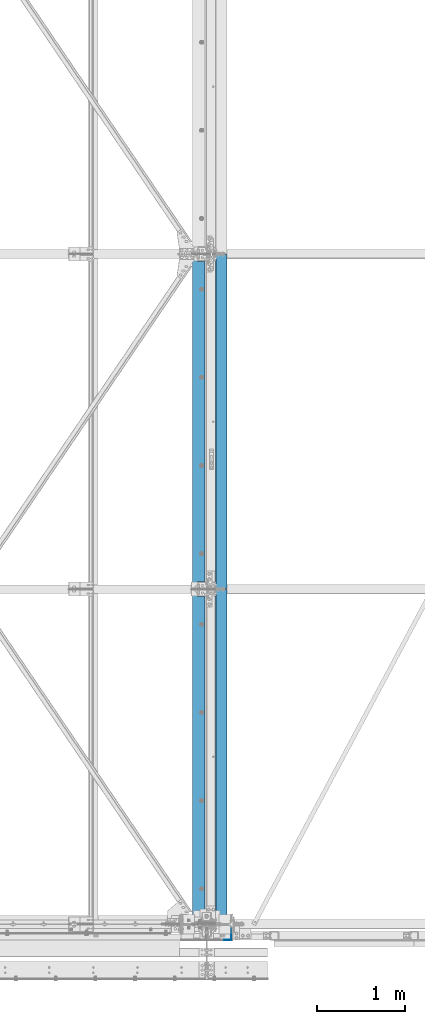
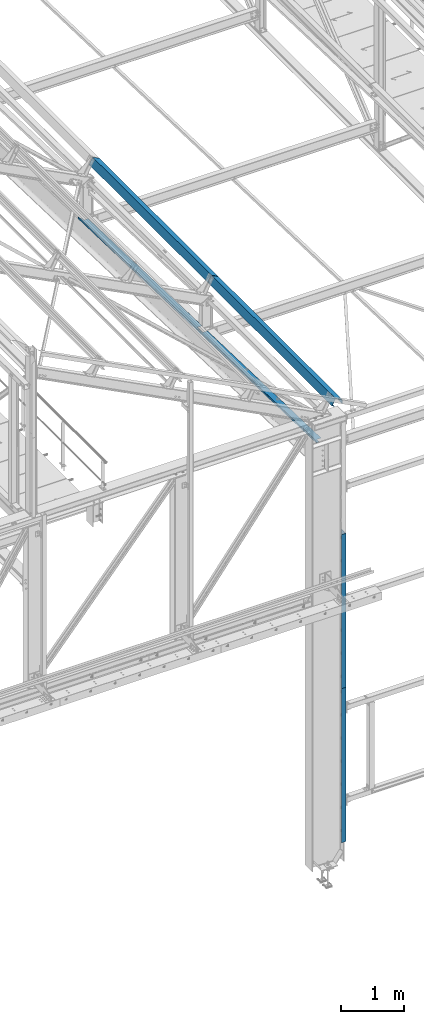
# One storey, part 348 of 496: 6 beams, 6 elements without a shape of their own.
"""IFC2X3 building model written with IfcOpenShell, lengths in millimetres."""

from ifc_helpers import new_model, si_unit, frame, origin_with_axes, place, context, subcontext, project, spatial, faceted_brep, material, type_object, element, aggregate, save


model = new_model("IFC2X3")

# Units and contexts
model_context = context("Model", 3, precision=1e-05, world=origin_with_axes())
body_context = subcontext(model_context, "Body", "Model", "MODEL_VIEW")
ifc_project = project(units=[si_unit("LENGTHUNIT", "METRE", prefix="MILLI"), si_unit("AREAUNIT", "SQUARE_METRE"), si_unit("VOLUMEUNIT", "CUBIC_METRE"), si_unit("MASSUNIT", "GRAM", prefix="KILO"), si_unit("TIMEUNIT", "SECOND"), si_unit("PLANEANGLEUNIT", "RADIAN"), si_unit("SOLIDANGLEUNIT", "STERADIAN"), si_unit("THERMODYNAMICTEMPERATUREUNIT", "DEGREE_CELSIUS"), si_unit("LUMINOUSINTENSITYUNIT", "LUMEN")], contexts=[model_context])

# Site, building, storey
site_placement = place(None, origin_with_axes())
site = spatial("IfcSite", under=ifc_project, at=site_placement, CompositionType="ELEMENT")
building_placement = place(site_placement, origin_with_axes())
building = spatial("IfcBuilding", under=site, at=building_placement, Name="Undefined", CompositionType="ELEMENT")
storey_placement = place(building_placement, origin_with_axes())
storey = spatial("IfcBuildingStorey", under=building, at=storey_placement, Name="Undefined", CompositionType="ELEMENT", Elevation=0.0)

# Assembly, beam
assembly_1_placement = place(storey_placement, origin_with_axes())
assembly_1 = element("IfcElementAssembly", 1, at=assembly_1_placement, inside=storey, Name="SHED", AssemblyPlace="NOTDEFINED", PredefinedType="NOTDEFINED")
ifc_material = material(Name="Undefined/S235-E24")
beam_type_1 = type_object("IfcBeamType", PredefinedType="NOTDEFINED")
beam_1_placement = place(assembly_1_placement, frame((28966.3687317403, 5700.00024422104, 8772.7482869049), z_axis=(0.0, 1.0, 0.0), x_axis=(-0.887870604061621, -1.29999898490562e-08, 0.460093241031915)))
beam_1 = element("IfcBeam", 2, at=beam_1_placement, type_object=beam_type_1, material=ifc_material, Name="SHED", context=body_context, shape_type="Brep", body=[
    faceted_brep([(-3.49427864421159e-08, -1.49999999999636, -1895.0), (-3.52956703864038e-08, -1.5, 1895.0), (3.49573383573443e-08, 1.5, 1895.0), (3.53102223016322e-08, 1.5, -1895.0), (47.0000011861484, 1.499998899395, 1895.0), (47.0000011898519, 1.49999889939863, -1895.0), (50.0000011927114, -1.50000117085074, -1895.0), (50.0000011890152, -1.50000117085438, 1895.0), (47.000001059947, 135.500002207569, 1895.00000000012), (47.0000010603762, 135.500002214732, -1894.99999999988), (50.0000010575095, 138.500002217588, -1894.99999999987), (50.0000010570839, 138.500002210421, 1895.00000000013), (-88.1757271770839, 135.5000020808, 1895.00000000025), (-88.1757271818278, 135.500002084245, -1894.99999999975), (-90.0000023299144, 138.50000208251, -1894.99999999975), (-90.0000023251705, 138.500002079061, 1895.00000000025), (-124.143850124739, 66.0900733967574, 1895.00000000026), (-124.143850129109, 66.0900733984818, -1894.99999999974), (-126.807461936929, 67.4703531198502, 1895.00000000026), (-126.807461941291, 67.4703531215746, -1894.99999999974)], [[[0, 1, 2, 3]], [[3, 2, 4, 5]], [[1, 0, 6, 7]], [[5, 4, 8, 9]], [[7, 6, 10, 11]], [[9, 8, 12, 13]], [[11, 10, 14, 15]], [[13, 12, 16, 17]], [[12, 8, 4, 2, 1, 7, 11, 15, 18, 16]], [[15, 14, 19, 18]], [[14, 10, 6, 0, 3, 5, 9, 13, 17, 19]], [[18, 19, 17, 16]]]),
])
aggregate(assembly_1, [beam_1])

assembly_2_placement = place(storey_placement, origin_with_axes())
assembly_2 = element("IfcElementAssembly", 3, at=assembly_2_placement, inside=storey, AssemblyPlace="NOTDEFINED", PredefinedType="NOTDEFINED")
beam_type_2 = type_object("IfcBeamType", PredefinedType="NOTDEFINED")
beam_2_placement = place(assembly_2_placement, frame((29080.9999677201, -177.499999406672, 4750.0000156124), z_axis=(0.0, 0.0, 1.0), x_axis=(1.0, 0.0, 0.0)))
beam_2 = element("IfcBeam", 4, at=beam_2_placement, type_object=beam_type_2, material=ifc_material, context=body_context, shape_type="Brep", body=[
    faceted_brep([(80.0000295444333, 127.500000622947, 79.99218047872), (75.0000295444333, 127.500000587947, 79.99218047872), (75.000029964438, 67.4999918822368, 79.99218047872), (80.000029964438, 67.4999919172368, 79.99218047872), (75.000029964438, 67.4999918822368, 149.99218047872), (80.000029964438, 67.4999919172368, 149.99218047872), (80.0000295444333, 127.499991917239, 149.99218047872), (75.0000295444333, 127.500000587947, 149.99218047872), (-1.04046193882823e-09, -2.5, -1500.0), (-1.04046193882823e-09, -2.5, 1500.0), (1.04409991763532e-09, 2.5, 1500.0), (1.04409991763532e-09, 2.5, -1500.0), (75.0000304194364, 2.49999996867308, 1500.0), (75.0000304194364, 2.49999996867308, -1500.0), (80.0000304544374, -2.50000003341538, -1500.0), (75.0000295444333, 127.500000587947, -1500.0), (80.0000295444333, 127.500000622947, -1500.0), (80.0000304544374, -2.50000003341538, 1500.0), (80.0000295444333, 127.500000622947, 1500.0), (75.0000295444333, 127.500000587947, 1500.0)], [[[0, 1, 2, 3]], [[3, 2, 4, 5]], [[6, 5, 4, 7]], [[8, 9, 10, 11]], [[11, 10, 12, 13]], [[14, 8, 11, 13, 15, 16]], [[9, 8, 14, 17]], [[12, 10, 9, 17, 18, 19]], [[19, 18, 6, 7]], [[2, 1, 15, 13, 12, 19, 7, 4]], [[16, 15, 1, 0]], [[18, 17, 14, 16, 0, 3, 5, 6]]]),
])
aggregate(assembly_2, [beam_2])

assembly_3_placement = place(storey_placement, origin_with_axes())
assembly_3 = element("IfcElementAssembly", 5, at=assembly_3_placement, inside=storey, AssemblyPlace="NOTDEFINED", PredefinedType="NOTDEFINED")
beam_3_placement = place(assembly_3_placement, frame((29080.9999686844, -177.499999406672, 1750.00001560909), z_axis=(0.0, 0.0, 1.0), x_axis=(1.0, 0.0, 0.0)))
beam_3 = element("IfcBeam", 6, at=beam_3_placement, type_object=beam_type_2, material=ifc_material, context=body_context, shape_type="Brep", body=[
    faceted_brep([(80.000029544437, 127.500000622947, -820.003917564409), (75.000029544437, 127.500000587947, -820.003917564409), (75.000029964438, 67.5000005879541, -820.003917564409), (80.0000299644344, 67.5000006229541, -820.003917564409), (75.000029964438, 67.5000005879541, -750.003917564409), (80.0000299644344, 67.5000006229541, -750.003917564409), (80.000029544437, 127.500000622957, -750.003917564409), (75.000029544437, 127.500000587947, -750.003917564409), (-1.04046193882823e-09, -2.5, -1500.0), (-1.04046193882823e-09, -2.5, 1500.0), (1.04409991763532e-09, 2.5, 1500.0), (1.04409991763532e-09, 2.5, -1500.0), (75.0000304194364, 2.49999996867308, 1500.0), (75.0000304194364, 2.49999996867308, -1500.0), (80.0000304544374, -2.50000003341538, -1500.0), (75.0000295444333, 127.500000587947, -1500.0), (80.0000295444333, 127.500000622947, -1500.0), (80.0000304544374, -2.50000003341538, 1500.0), (80.0000295444333, 127.500000622947, 1500.0), (75.0000295444333, 127.500000587947, 1500.0), (80.000029544437, 127.500000622957, 1049.99608243647), (75.000029544437, 127.500000587947, 1049.99608243647), (80.0000299644416, 67.5000006229541, 1049.99608243647), (75.0000299644416, 67.5000005879541, 1049.99608243647), (80.0000299644416, 67.5000006229541, 979.996082436471), (75.0000299644416, 67.5000005879541, 979.996082436471), (80.000029544437, 127.500000622947, 979.996082436471), (75.000029544437, 127.500000587947, 979.996082436471)], [[[0, 1, 2, 3]], [[3, 2, 4, 5]], [[6, 5, 4, 7]], [[8, 9, 10, 11]], [[11, 10, 12, 13]], [[14, 8, 11, 13, 15, 16]], [[9, 8, 14, 17]], [[12, 10, 9, 17, 18, 19]], [[19, 18, 20, 21]], [[20, 22, 23, 21]], [[24, 25, 23, 22]], [[26, 27, 25, 24]], [[27, 26, 6, 7]], [[2, 1, 15, 13, 12, 19, 21, 23, 25, 27, 7, 4]], [[16, 15, 1, 0]], [[26, 24, 22, 20, 18, 17, 14, 16, 0, 3, 5, 6]]]),
])
aggregate(assembly_3, [beam_3])

assembly_4_placement = place(storey_placement, origin_with_axes())
assembly_4 = element("IfcElementAssembly", 7, at=assembly_4_placement, inside=storey, Name="POUTRE", AssemblyPlace="NOTDEFINED", PredefinedType="NOTDEFINED")
beam_type_3 = type_object("IfcBeamType", PredefinedType="NOTDEFINED")
beam_4_placement = place(assembly_4_placement, frame((28859.9999999999, 1899.71695010422, 7991.29997216435), z_axis=(0.0, 0.999506556345274, -0.0314108870109058), x_axis=(-1.0, 0.0, 0.0)))
beam_4 = element("IfcBeam", 8, at=beam_4_placement, type_object=beam_type_3, material=ifc_material, Name="POUTRE", context=body_context, shape_type="Brep", body=[
    faceted_brep([(84.9999999979264, 0.999999999923602, 1895.93800542073), (84.9999999999563, 0.999999999923602, 1815.93800543636), (84.9999999999563, -1.00000000007185, 1815.93800543636), (84.9999999979264, -1.00000000007731, 1895.93800542073), (7.27595761418343e-12, 1.00000000000182, 1815.93800543633), (0.0, -0.999999999999091, 1815.93800543633), (137.999999999782, 39.0000003423174, -1895.93800544089), (137.999999999767, 0.999999999872671, -1895.9380054409), (137.999999999796, 0.999999999875399, 1895.93800542073), (137.999999999782, 39.0000003423456, 1895.93800542075), (139.999999999782, 39.0000003423174, -1895.93800544089), (139.999999999782, 39.0000003423456, 1895.93800542075), (139.999999999767, -1.00000000012824, -1895.93800544091), (139.999999999796, -1.00000000012733, 1895.93800542073), (85.0000000000728, -1.00000000007822, -1895.93800544091), (85.0000000000728, 0.999999999920874, -1895.9380054409), (85.0000000000582, -1.00000000007913, -1815.93800540536), (85.0000000000582, 0.999999999921783, -1815.93800540536), (0.0, 1.0, -1815.93800540536), (-7.27595761418343e-12, -1.00000000000091, -1815.93800540536)], [[[0, 1, 2, 3]], [[4, 5, 2, 1]], [[6, 7, 8, 9]], [[10, 6, 9, 11]], [[12, 10, 11, 13]], [[7, 6, 10, 12, 14, 15]], [[15, 14, 16, 17]], [[18, 17, 16, 19]], [[0, 8, 7, 15, 17, 18, 4, 1]], [[13, 11, 9, 8, 0, 3]], [[19, 16, 14, 12, 13, 3, 2, 5]], [[18, 19, 5, 4]]]),
])
aggregate(assembly_4, [beam_4])

assembly_5_placement = place(storey_placement, origin_with_axes())
assembly_5 = element("IfcElementAssembly", 9, at=assembly_5_placement, inside=storey, Name="POUTRE", AssemblyPlace="NOTDEFINED", PredefinedType="NOTDEFINED")
beam_5_placement = place(assembly_5_placement, frame((28859.9999999999, 5699.71696464998, 7871.88016099719), z_axis=(0.0, 0.999506556345274, -0.0314108870109058), x_axis=(-1.0, 0.0, 0.0)))
beam_5 = element("IfcBeam", 10, at=beam_5_placement, type_object=beam_type_3, material=ifc_material, Name="POUTRE", context=body_context, shape_type="Brep", body=[
    faceted_brep([(84.9999999979264, 0.999999999923602, 1895.93800542073), (84.9999999999563, 0.999999999923602, 1815.93800543636), (84.9999999999563, -1.00000000007185, 1815.93800543636), (84.9999999979264, -1.00000000007731, 1895.93800542073), (7.27595761418343e-12, 1.00000000000182, 1815.93800543633), (0.0, -0.999999999999091, 1815.93800543633), (137.999999999782, 39.0000003423174, -1895.93800544089), (137.999999999767, 0.999999999872671, -1895.9380054409), (137.999999999796, 0.999999999875399, 1895.93800542073), (137.999999999782, 39.0000003423456, 1895.93800542075), (139.999999999782, 39.0000003423174, -1895.93800544089), (139.999999999782, 39.0000003423456, 1895.93800542075), (139.999999999767, -1.00000000012824, -1895.93800544091), (139.999999999796, -1.00000000012733, 1895.93800542073), (85.0000000000728, -1.00000000007822, -1895.93800544091), (85.0000000000728, 0.999999999920874, -1895.9380054409), (85.0000000000582, -1.00000000007913, -1815.93800540536), (85.0000000000582, 0.999999999921783, -1815.93800540536), (0.0, 1.0, -1815.93800540536), (-7.27595761418343e-12, -1.00000000000091, -1815.93800540536)], [[[0, 1, 2, 3]], [[4, 5, 2, 1]], [[6, 7, 8, 9]], [[10, 6, 9, 11]], [[12, 10, 11, 13]], [[7, 6, 10, 12, 14, 15]], [[15, 14, 16, 17]], [[18, 17, 16, 19]], [[0, 8, 7, 15, 17, 18, 4, 1]], [[13, 11, 9, 8, 0, 3]], [[19, 16, 14, 12, 13, 3, 2, 5]], [[18, 19, 5, 4]]]),
])
aggregate(assembly_5, [beam_5])

assembly_6_placement = place(storey_placement, origin_with_axes())
assembly_6 = element("IfcElementAssembly", 11, at=assembly_6_placement, inside=storey, Name="SHED", AssemblyPlace="NOTDEFINED", PredefinedType="NOTDEFINED")
beam_type_4 = type_object("IfcBeamType", PredefinedType="NOTDEFINED")
beam_6_placement = place(assembly_6_placement, frame((28966.3687317403, 1820.00024422104, 8772.74828690799), z_axis=(0.0, 1.0, 0.0), x_axis=(-0.887870604061621, -1.29999898490562e-08, 0.460093241031915)))
beam_6 = element("IfcBeam", 12, at=beam_6_placement, type_object=beam_type_4, material=ifc_material, Name="SHED", context=body_context, shape_type="Brep", body=[
    faceted_brep([(-4.57293936051428e-09, -1.5, -1975.0), (-2.82670953311026e-09, -1.49999999999636, 1975.0), (4.57293936051428e-09, 1.50000000000364, 1975.0), (2.82307155430317e-09, 1.50000000000364, -1975.0), (46.9999982244844, 1.49999988410855, 1974.99999999998), (46.9999982243717, 1.49999988410491, -1975.00000000002), (49.9999982228783, -1.50000012329474, -1975.00000000002), (49.9999982229929, -1.5000001232911, 1974.99999999998), (46.9999982920745, 135.499998582192, 1975.00000000004), (46.9999982902773, 135.499998584666, -1974.99999999997), (49.9999982917725, 138.499998490119, -1974.99999999997), (49.9999982935697, 138.499998487649, 1975.00000000004), (-88.1757271768438, 135.500002081015, 1975.00000000017), (-88.1757271812858, 135.500002083256, -1974.99999999983), (-90.0000045074175, 138.500002901914, -1974.99999999987), (-90.0000045038087, 138.50000290012, 1975.00000000013), (-124.14385012443, 66.0900733969975, 1975.0000000002), (-124.14385012869, 66.0900733978888, -1974.9999999998), (-126.807461936613, 67.4703531200939, 1975.0000000002), (-126.807461940876, 67.4703531209852, -1974.9999999998)], [[[0, 1, 2, 3]], [[3, 2, 4, 5]], [[1, 0, 6, 7]], [[5, 4, 8, 9]], [[7, 6, 10, 11]], [[9, 8, 12, 13]], [[11, 10, 14, 15]], [[13, 12, 16, 17]], [[12, 8, 4, 2, 1, 7, 11, 15, 18, 16]], [[15, 14, 19, 18]], [[14, 10, 6, 0, 3, 5, 9, 13, 17, 19]], [[18, 19, 17, 16]]]),
])
aggregate(assembly_6, [beam_6])

save(model, "model.ifc")
